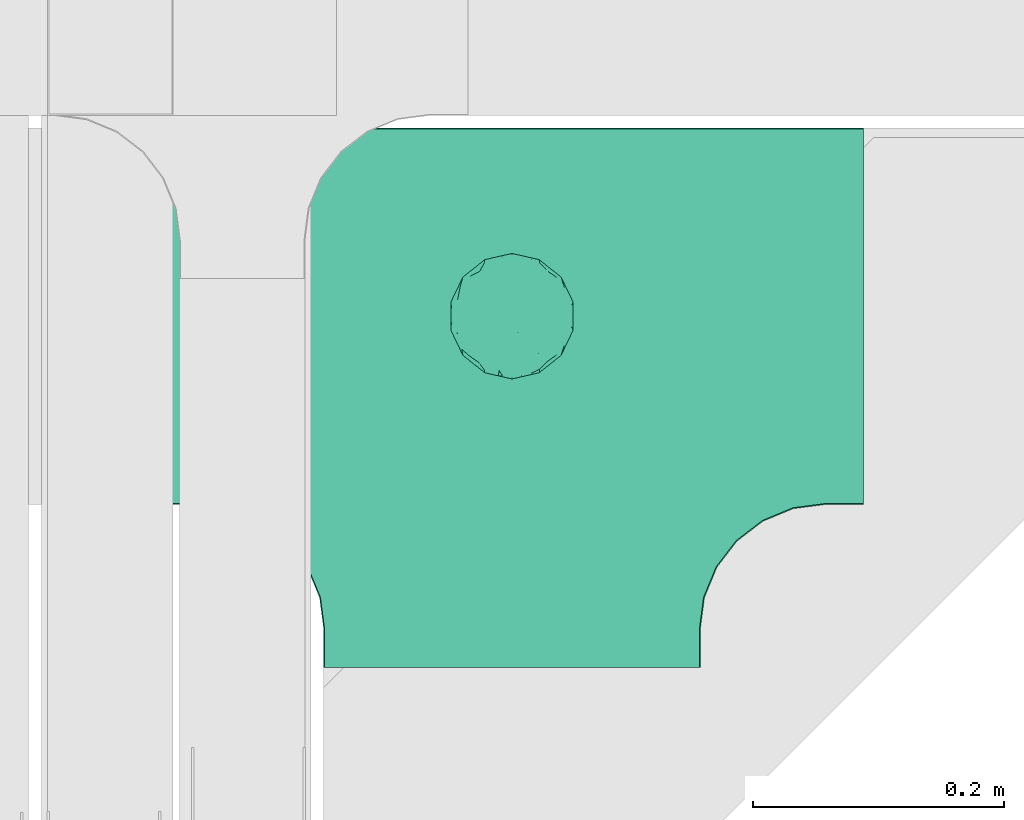
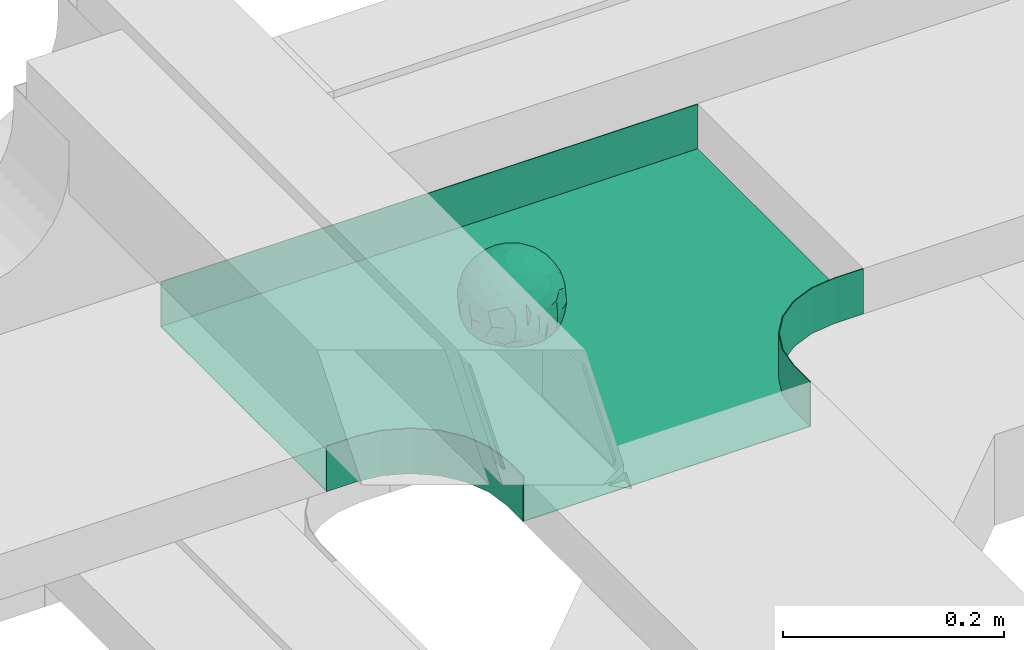
# One storey, part 29 of 33: 1 flow fitting.
"""IFC2X3 building model written with IfcOpenShell, lengths in millimetres."""

from ifc_helpers import new_model, entity, si_unit, converted_unit, derived_unit, direction, frame, origin, place, context, subcontext, project, spatial, faceted_brep, source, transform, mapped, material, material_list, type_object, type_shapes, element, save


model = new_model("IFC2X3")

# Units and contexts
model_context = context("Model", 3, precision=0.01, world=origin(), true_north=direction((6.12303176911189e-17, 1.0)))
body_context = subcontext(model_context, "Body", "Model", "MODEL_VIEW")
ifc_project = project(units=[si_unit("LENGTHUNIT", "METRE", prefix="MILLI"), si_unit("AREAUNIT", "SQUARE_METRE"), si_unit("VOLUMEUNIT", "CUBIC_METRE"), converted_unit("PLANEANGLEUNIT", "DEGREE", entity("IfcRatioMeasure", 0.0174532925199433), si_unit("PLANEANGLEUNIT", "RADIAN"), dimensions=[0, 0, 0, 0, 0, 0, 0]), si_unit("MASSUNIT", "GRAM", prefix="KILO"), derived_unit("MASSDENSITYUNIT", [(si_unit("MASSUNIT", "GRAM", prefix="KILO"), 1), (si_unit("LENGTHUNIT", "METRE"), -3)]), derived_unit("MOMENTOFINERTIAUNIT", [(si_unit("LENGTHUNIT", "METRE"), 4)]), si_unit("TIMEUNIT", "SECOND"), si_unit("FREQUENCYUNIT", "HERTZ"), si_unit("THERMODYNAMICTEMPERATUREUNIT", "DEGREE_CELSIUS"), derived_unit("THERMALTRANSMITTANCEUNIT", [(si_unit("MASSUNIT", "GRAM", prefix="KILO"), 1), (si_unit("THERMODYNAMICTEMPERATUREUNIT", "KELVIN"), -1), (si_unit("TIMEUNIT", "SECOND"), -3)]), derived_unit("VOLUMETRICFLOWRATEUNIT", [(si_unit("LENGTHUNIT", "METRE"), 3), (si_unit("TIMEUNIT", "SECOND"), -1)]), derived_unit("MASSFLOWRATEUNIT", [(si_unit("MASSUNIT", "GRAM", prefix="KILO"), 1), (si_unit("TIMEUNIT", "SECOND"), -1)]), derived_unit("ROTATIONALFREQUENCYUNIT", [(si_unit("TIMEUNIT", "SECOND"), -1)]), si_unit("ELECTRICCURRENTUNIT", "AMPERE"), si_unit("ELECTRICVOLTAGEUNIT", "VOLT"), si_unit("POWERUNIT", "WATT"), si_unit("FORCEUNIT", "NEWTON", prefix="KILO"), si_unit("ILLUMINANCEUNIT", "LUX"), si_unit("LUMINOUSFLUXUNIT", "LUMEN"), si_unit("LUMINOUSINTENSITYUNIT", "CANDELA"), derived_unit("USERDEFINED", [(si_unit("MASSUNIT", "GRAM", prefix="KILO"), -1), (si_unit("LENGTHUNIT", "METRE"), -2), (si_unit("TIMEUNIT", "SECOND"), 3), (si_unit("LUMINOUSFLUXUNIT", "LUMEN"), 1)]), derived_unit("LINEARVELOCITYUNIT", [(si_unit("LENGTHUNIT", "METRE"), 1), (si_unit("TIMEUNIT", "SECOND"), -1)]), si_unit("PRESSUREUNIT", "PASCAL"), derived_unit("USERDEFINED", [(si_unit("LENGTHUNIT", "METRE"), -2), (si_unit("MASSUNIT", "GRAM", prefix="KILO"), 1), (si_unit("TIMEUNIT", "SECOND"), -2)]), derived_unit("LINEARFORCEUNIT", [(si_unit("MASSUNIT", "GRAM", prefix="KILO"), 1), (si_unit("LENGTHUNIT", "METRE"), 1), (si_unit("TIMEUNIT", "SECOND"), -2), (si_unit("LENGTHUNIT", "METRE"), -1)]), derived_unit("PLANARFORCEUNIT", [(si_unit("MASSUNIT", "GRAM", prefix="KILO"), 1), (si_unit("LENGTHUNIT", "METRE"), 1), (si_unit("TIMEUNIT", "SECOND"), -2), (si_unit("LENGTHUNIT", "METRE"), -2)])], contexts=[model_context])

# Site, building, storey
site_placement = place(None, frame((0.0, -0.00077364408347762, 0.0)))
site = spatial("IfcSite", under=ifc_project, at=site_placement, CompositionType="ELEMENT")
building_placement = place(site_placement, origin())
building = spatial("IfcBuilding", under=site, at=building_placement, CompositionType="ELEMENT")
storey_placement = place(building_placement, frame((0.0, 0.0, 8100.0)))
storey = spatial("IfcBuildingStorey", under=building, at=storey_placement, CompositionType="ELEMENT", Elevation=8100.0)

# Flow fitting
ifc_material_1 = material()
ifc_material_2 = material()
ifc_material_list = material_list([ifc_material_1, ifc_material_2])
cable_carrier_fitting_type = type_object("IfcCableCarrierFittingType", PredefinedType="NOTDEFINED", material=ifc_material_1)
shared_shape = source(origin(), body_context, "Body", "Brep", [
    faceted_brep([(43.65414201495, -13.6159823941412, -20.221792907194), (44.7734537304832, 0.0, -22.2561865791168), (48.2627667869764, -5.5982238187369, -11.8053052540677), (16.6591030416451, 5.32882774998004, -46.8409850521773), (11.5556000970565, -8.32997143460759, -47.9278591457525), (2.01883462715812, 2.6979389970297, -49.8863250993269), (-7.81264210311725, -35.946586740035, -33.8645171988286), (-17.2052206683237, -38.2719861359275, -27.1888848422606), (-11.1277274207927, -27.3202044092451, -40.3705352142543), (37.7030088371667, -7.24923843471304, -32.0301680723234), (10.6384317789277, 26.5155476513889, -41.0335168128579), (19.2127839264957, 19.8412508508062, -41.6796556903778), (10.4192511908907, 17.8098221318595, -45.5439286870577), (48.7463956090969, 0.0, 0.0), (48.0667721403428, 6.51594663441988, -12.1296271775358), (-37.4554170352858, 12.1627069007925, -30.8084451986326), (-31.3452178059555, 12.1462454498318, -37.0127821457472), (-38.0909108580228, 3.52194087904066, -32.1974912446565), (48.7463956090969, 11.1260466978072, 0.0), (9.66670567763161, 42.5651334019307, -24.3877883338551), (17.4761229293595, 37.974251726212, -27.4324868211278), (8.3452685270067, 35.3634447252368, -34.3479733081336), (36.7018152786982, 20.4309971840494, -27.121045505536), (28.2201055605836, 12.5803931374896, -39.3110588849404), (28.3969378462537, 24.0066360557188, -33.4259681422047), (37.1036906899333, 7.75177236926259, -32.6071489449891), (30.3928805396455, 38.1114667440203, 0.0), (34.7422273315263, 34.6429784184742, 0.0), (32.9402906787036, 32.1278050479557, -19.5637775698511), (26.0435337477646, 41.5799550695664, 0.0), (-44.7734518080776, 0.0, -22.2561904464559), (-35.9183276906112, -8.71634506105637, -33.6734177755349), (-42.698067512074, -12.1858404892465, -22.9865247983333), (5.42354673897514, -48.7621108487887, 0.0), (2.92058716488888e-07, -48.7843224693665, -10.9585528791684), (7.58713024513234, -47.4313421101439, -13.8817592643935), (33.995370401777, -31.6485911362954, -18.5116576873667), (40.0066375577234, -26.2448741379086, -14.5146661281262), (30.3928805396453, -38.1114667440373, 0.0), (-47.5540080368347, -8.6499737676748, -12.798213682019), (43.918984866252, -21.1502683953847, 0.0), (-47.5463631702337, 8.67950108284767, -12.8066236860544), (-43.9189848662407, 21.1502683953677, 0.0), (-41.5587306666804, 23.544384411141, -14.7828910593852), (-36.7018137075475, 20.43099797302, -27.1210470373429), (-42.6812093094125, 12.162707383776, -23.0300438771125), (-0.0435489182880873, -44.6798423199703, -22.4434799831651), (43.3459115209922, 13.125713179152, -21.1860238825719), (-9.67158541810518, -42.815796006327, -23.9430166822217), (2.9348104480415, -38.3026865671621, -32.0045479482528), (10.5768620896568, -32.3565839798164, -36.6221444141874), (17.476122931187, -37.9742517249799, -27.4324868216925), (29.4150529887209, -14.2918330913411, -37.8219270339311), (29.2594402117981, 0.0, -40.5448536622337), (-34.742227331515, 34.6429784184742, 0.0), (-35.5934709721032, 30.8679809236437, -16.7413433706631), (16.2706402169142, 46.2863325463322, 0.0), (15.3978227309257, 45.3692296018892, -14.301750259225), (10.8470934779447, 47.524221697552, 0.0), (-22.0930685137321, 42.2576087042555, -15.0396419586498), (-16.2706402169028, 46.2863325463322, 0.0), (-15.3976096147999, 45.3685960862683, -14.3039892096614), (-35.5741674477324, -30.877857614309, -16.7641438657341), (-34.7422273315149, -34.6429784184913, 0.0), (-41.544749127214, -23.5699215759022, -14.7814957586296), (-21.2012609977656, -29.9118129495041, -33.9969113035032), (-22.0930685137892, -42.2576087036302, -15.0396419603704), (-28.5890959469058, -35.7745555449591, -20.0709932115786), (27.967317375364, -26.9235432392394, -31.5111405422078), (26.5630985649032, -36.7540375314827, -21.0604491824418), (-4.69743067705244, -12.8233951627736, -48.0988012484001), (-3.71385705669819, -22.0483048804436, -44.7222485756373), (7.046128924104e-07, -29.8515321197025, -40.1109215813634), (-8.78090686085946, 23.4705297392872, -43.266960933916), (-10.7087237416586, 12.1533783795858, -47.3034737602475), (-19.1851128431225, 19.8122800241045, -41.7061746680507), (19.2127839279743, -19.841250849511, -41.6796556903208), (10.2736167511021, -43.2535488218696, -22.8819429499797), (-16.2706402169027, -46.2863325463492, 0.0), (-15.4179487650123, -45.4307793041134, -14.0830091848577), (-10.8470934779332, -47.524221697569, 0.0), (-21.6941869558721, -45.0484433951294, 0.0), (-26.043533747753, -41.5799550695834, 0.0), (-30.3928805396339, -38.1114667440373, 0.0), (-26.9077773704145, -11.7097120961444, -40.4827637348157), (-28.5735237959864, -22.531789977659, -34.2909926698312), (-14.3485559949731, 0.554718003800719, -47.8937493708156), (20.3912706461748, 29.6966950280778, -34.6742323035854), (25.8798715159051, 35.5620355309087, -23.7817972243053), (-1.90439589452332, 38.2956374757213, -32.090768557389), (-0.0435489197807358, 44.6798423204566, -22.4434799821603), (-9.54280395759116, 42.6678856642021, -24.2566779582937), (-10.1209262269152, 33.0365306692783, -36.140759450321), (-17.2052206685055, 38.2719861378047, -27.1888848394794), (-28.5890959468196, 35.7745555453602, -20.0709932109564), (-30.3928805396341, 38.1114667440203, 0.0), (-26.0435337477532, 41.5799550695664, 0.0), (-21.6941869558723, 45.0484433951125, 0.0), (0.920553890736952, 16.9936143333855, -47.0145685125519), (7.01705705346737e-07, 29.8515321215381, -40.1109215799846), (-28.4299335912282, 23.6392950735915, -33.6589156750601), (22.0754283900311, -42.7194435884069, -13.7012627481666), (0.0, -50.0, 0.0), (-7.98433520770671, 47.2879675743241, -14.1456181900809), (-10.8470934779333, 47.524221697552, 0.0), (-5.42354673896381, 48.7621108487718, 0.0), (-39.0915741233958, -31.1744900929452, 0.0), (-36.7018137083218, -20.4309979729983, -27.1210470363242), (-20.0503020227076, 29.8835350153312, -34.7125297808217), (48.7463956090969, -11.1260466978243, 0.0), (36.7018152787698, -20.430997183803, -27.1210455056374), (39.0915741234071, -31.1744900929452, 0.0), (43.9189848662521, 21.1502683953677, 0.0), (41.0372234357161, 24.481336168204, -14.7176924857918), (21.4315363761966, -9.86715979165204, -44.0831986838696), (19.8461085062156, -30.3026908878047, -34.4656191315041), (26.0435337477644, -41.5799550695834, 0.0), (8.27678352490751, -22.6176025005053, -43.8171075221857), (-19.1851128386707, -19.8122800229913, -41.7061746706354), (-17.559283921422, -9.66340012518247, -45.8070982074481), (-29.2594384269524, -1.64502744759432e-09, -40.5448549502702), (-22.2759109836818, 8.45458562997746, -43.957977338265), (21.6941869558835, -45.0484433951294, 0.0), (-7.7537430917927, -47.3248906716555, -14.1504131029038), (22.0929359888287, 42.3611643932195, -14.7456410726513), (21.6941869558837, 45.0484433951125, 0.0), (7.94480963874029, 47.2524194975214, -14.285966940796), (5.42354673897518, 48.7621108487718, 0.0), (-43.9189848662406, -21.1502683953848, 0.0), (-39.0915741233959, 31.1744900929281, 0.0), (-48.7463956090855, 11.1260466978072, 0.0), (-48.7463956090855, -11.1260466978243, 0.0), (-48.7463956090855, 0.0, 0.0), (0.0, 50.0, 0.0), (2.95674852821199e-07, 48.76542105366, -11.0423597776141), (-5.42354673896377, -48.7621108487887, 0.0), (16.2706402169141, -46.2863325463492, 0.0), (10.8470934779446, -47.524221697569, 0.0), (39.0915741234072, 31.1744900929281, 0.0), (34.7422273315262, -34.6429784184913, 0.0), (-43.6541417785539, -13.6159824952714, 20.2217933494142), (-44.7734534735007, 0.0, 22.2561870960884), (-48.2627667188257, -5.59822380837423, 11.8053055375658), (-16.6591016552529, 5.32882757852047, 46.8409855647676), (-11.5555985538933, -8.32997141356845, 47.9278595214841), (-2.01883285210585, 2.69793886619285, 49.8863251782511), (7.81264298940045, -35.9465866899564, 33.8645170475355), (17.2052219498432, -38.2719853643866, 27.1888851173795), (11.1277291939633, -27.3202042660781, 40.370534822402), (-37.7030082707847, -7.24923849358482, 32.0301687256941), (-10.6384306361632, 26.5155474098453, 41.0335172652288), (-19.2127828542464, 19.8412506695278, 41.6796562709507), (-10.419249902145, 17.8098220464058, 45.5439290153173), (-48.0667720467311, 6.51594672713361, 12.1296274986609), (37.4554198551597, 12.1627053911885, 30.8084423663635), (31.3452204336626, 12.1462444514283, 37.0127802480704), (38.0909129847824, 3.52193921618223, 32.1974889105362), (-9.66670492251031, 42.565133342123, 24.3877887375616), (-17.4761222809685, 37.9742516795029, 27.4324872988574), (-8.34526747232003, 35.3634445391436, 34.3479737559899), (-36.7018147879525, 20.4309972885889, 27.1210460908894), (-28.2201045883605, 12.5803929822385, 39.3110596325575), (-28.3969371324566, 24.0066357536882, 33.4259689655335), (-37.1036900366786, 7.75177247673037, 32.6071496627812), (-32.9402901163369, 32.1278052689131, 19.5637781538672), (44.773453728735, 0.0, 22.2561865826485), (35.9183286182219, -8.71634518545332, 33.6734167539099), (42.6980684782056, -12.1858381773451, 22.9865242293622), (-5.1564557811304e-08, -48.7843224155168, 10.9585531189064), (-7.58712982046247, -47.4313421866568, 13.8817592350767), (-33.9953700157816, -31.6485912778883, 18.5116581541388), (-40.0066373233245, -26.2448743223541, 14.5146664406737), (47.5540088657557, -8.64997340643016, 12.7982108462298), (47.5463641063755, 8.67950029611492, 12.8066207437518), (41.5587323717035, 23.5443822102692, 14.7828897714275), (36.7018153946169, 20.4309968399072, 27.121045607934), (42.6812105193328, 12.1627054070682, 23.0300426787683), (0.0435498934198039, -44.6798421141237, 22.4434803910813), (-43.3459112327239, 13.1257132261269, 21.1860244432478), (9.6715868653752, -42.8157959611257, 23.9430161784588), (-2.93481023367521, -38.3026862522726, 32.0045483447802), (-10.5768615382775, -32.3565831315815, 36.6221453228799), (-17.4761222811971, -37.9742516793303, 27.4324872989742), (-29.4150522011614, -14.2918331221065, 37.8219276348162), (-29.259439267976, 0.0, 40.5448543433553), (35.593472529025, 30.867979902287, 16.7413419437535), (-15.3978225621776, 45.3692295068837, 14.3017507422931), (22.0930688164668, 42.2576085856364, 15.0396418472572), (15.3976099169387, 45.3685960801975, 14.3039889037045), (35.5741692798952, -30.8778564526781, 16.7641421174582), (41.5447510295928, -23.5699190140567, 14.7814944968718), (21.2012629219892, -29.9118119699372, 33.9969109653959), (22.0930688164889, -42.2576085855628, 15.039641847479), (28.5890966709526, -35.7745557157875, 20.0709918757936), (-27.9673166448933, -26.9235432178776, 31.5111412087844), (-26.5630981091642, -36.7540374223405, 21.0604499477277), (4.69743244094294, -12.8233948182002, 48.0988011680158), (3.71385918047916, -22.0483045188225, 44.7222485775695), (6.0892732202368e-07, -29.8515316280668, 40.1109219472655), (8.78090833347225, 23.4705290601204, 43.2669610034903), (10.7087255323208, 12.1533779204354, 47.3034734728551), (19.1851144535653, 19.8122792782791, 41.7061742815566), (-19.212782854423, -19.8412506693283, 41.6796562709723), (-10.2736163541564, -43.2535491498667, 22.8819425082012), (15.4179491053271, -45.430779442795, 14.0830083649343), (26.9077783310918, -11.7097109554472, 40.4827634262511), (28.5735255699879, -22.531788297607, 34.2909922955619), (14.3485579041194, 0.554717908736034, 47.893748799971), (-20.3912698186306, 29.6966949125693, 34.674232889184), (-25.8798708903081, 35.5620354347035, 23.7817980489561), (1.90439718168615, 38.2956370656312, 32.0907689704016), (0.0435498935700709, 44.6798421141929, 22.4434803909095), (9.54280511870019, 42.6678852802435, 24.2566781769111), (10.1209277017953, 33.036529901429, 36.1407597392074), (17.2052219497738, 38.2719853646937, 27.1888851169673), (28.5890966709116, 35.7745557157488, 20.0709918758907), (-0.920552500958269, 16.993613961591, 47.0145686741652), (6.09264554473049e-07, 29.8515316283504, 40.1109219470418), (28.4299352793349, 23.6392936643312, 33.6589152389788), (-22.0754282965694, -42.7194435788052, 13.7012629286858), (7.9843354212563, 47.2879674404261, 14.1456185171795), (36.7018153946056, -20.4309968401043, 27.1210456078136), (20.0503035663584, 29.8835340747136, 34.7125296989797), (-36.7018147879654, -20.4309972885437, 27.1210460909186), (-41.0372232425556, 24.4813362747081, 14.7176928472045), (-21.4315352776288, -9.8671595900376, 44.0831992630873), (-19.8461080318002, -30.3026912052829, 34.4656191255603), (-8.27678185920825, -22.617601585775, 43.8171083090061), (19.1851144530605, -19.8122792780652, 41.7061742818985), (17.5592847966676, -9.6634000411993, 45.8070978896755), (29.259440221343, 0.0, 40.5448536553604), (22.2759127990671, 8.45458631346954, 43.9579762868721), (7.75374356219277, -47.3248906381916, 14.1504129570858), (-22.0929358819219, 42.3611643749655, 14.7456412852645), (-7.94480944914509, 47.2524194744515, 14.2859671225497), (-5.23333520595152e-08, 48.7654210084985, 11.0423599770715)], [[[0, 1, 2]], [[3, 4, 5]], [[6, 7, 8]], [[1, 0, 9]], [[10, 11, 12]], [[13, 2, 14]], [[15, 16, 17]], [[14, 18, 13]], [[19, 20, 21]], [[22, 23, 24]], [[1, 9, 25]], [[26, 27, 28, 29]], [[30, 31, 32]], [[33, 34, 35]], [[36, 37, 38]], [[32, 39, 30]], [[2, 40, 0]], [[23, 22, 25]], [[41, 42, 43]], [[44, 15, 45]], [[46, 35, 34]], [[25, 22, 47]], [[31, 30, 17]], [[48, 49, 46]], [[50, 51, 49]], [[52, 53, 9]], [[43, 54, 55]], [[56, 57, 58]], [[59, 60, 61]], [[62, 63, 64]], [[8, 7, 65]], [[7, 66, 67]], [[68, 36, 69]], [[70, 5, 4]], [[8, 71, 72]], [[73, 74, 75]], [[68, 76, 52]], [[77, 46, 49]], [[78, 79, 80]], [[7, 6, 48]], [[67, 81, 82, 83]], [[84, 85, 31]], [[85, 65, 67]], [[70, 86, 5]], [[23, 3, 11]], [[21, 87, 10]], [[21, 20, 87]], [[28, 24, 88]], [[19, 89, 90]], [[91, 90, 89]], [[91, 92, 93]], [[94, 95, 96, 97]], [[98, 99, 10]], [[100, 16, 44]], [[77, 51, 101]], [[33, 102, 34]], [[103, 91, 61]], [[93, 59, 61]], [[104, 105, 103]], [[106, 64, 63]], [[107, 31, 85]], [[100, 94, 108]], [[108, 93, 92]], [[43, 55, 44]], [[0, 40, 37]], [[2, 13, 109]], [[2, 1, 14]], [[110, 9, 0]], [[2, 109, 40]], [[37, 40, 111]], [[47, 14, 1]], [[112, 14, 47]], [[113, 112, 47]], [[112, 18, 14]], [[47, 22, 113]], [[52, 9, 110]], [[53, 25, 9]], [[25, 47, 1]], [[23, 25, 53]], [[68, 52, 110]], [[76, 4, 114]], [[51, 115, 69]], [[50, 115, 51]], [[110, 36, 68]], [[3, 23, 53]], [[23, 11, 24]], [[52, 76, 114]], [[98, 12, 5]], [[11, 87, 24]], [[24, 28, 22]], [[87, 88, 24]], [[36, 116, 69]], [[28, 27, 113]], [[114, 3, 53]], [[76, 115, 117]], [[70, 4, 117]], [[118, 84, 119]], [[119, 70, 118]], [[120, 16, 121]], [[37, 36, 110]], [[116, 36, 38]], [[116, 122, 69]], [[34, 123, 46]], [[10, 87, 11]], [[87, 20, 88]], [[12, 98, 10]], [[10, 99, 21]], [[74, 5, 86]], [[73, 75, 108]], [[124, 56, 125]], [[124, 29, 88]], [[89, 21, 99]], [[21, 89, 19]], [[92, 89, 99]], [[89, 92, 91]], [[126, 127, 58]], [[88, 29, 28]], [[20, 57, 124]], [[88, 20, 124]], [[57, 20, 19]], [[73, 92, 99]], [[92, 73, 108]], [[99, 98, 73]], [[74, 86, 121]], [[73, 98, 74]], [[5, 74, 98]], [[100, 108, 75]], [[94, 93, 108]], [[86, 120, 121]], [[100, 44, 55]], [[75, 16, 100]], [[17, 16, 120]], [[31, 17, 120]], [[17, 30, 45]], [[84, 31, 120]], [[31, 107, 32]], [[41, 45, 30]], [[43, 44, 45]], [[107, 64, 32]], [[39, 64, 128]], [[30, 39, 41]], [[129, 43, 42]], [[41, 130, 42]], [[43, 45, 41]], [[62, 83, 63]], [[95, 94, 55]], [[100, 55, 94]], [[64, 107, 62]], [[131, 39, 128]], [[64, 106, 128]], [[85, 62, 107]], [[67, 83, 62]], [[39, 32, 64]], [[130, 41, 132]], [[59, 97, 60]], [[133, 127, 134]], [[59, 94, 97]], [[104, 61, 60]], [[94, 59, 93]], [[126, 134, 127]], [[126, 58, 57]], [[19, 90, 126]], [[134, 105, 133]], [[126, 90, 134]], [[103, 90, 91]], [[105, 134, 103]], [[90, 103, 134]], [[119, 120, 86]], [[84, 118, 85]], [[65, 85, 118]], [[62, 85, 67]], [[8, 65, 118]], [[67, 65, 7]], [[71, 118, 70]], [[8, 72, 6]], [[49, 6, 72]], [[6, 49, 48]], [[50, 49, 72]], [[77, 49, 51]], [[101, 69, 122]], [[123, 34, 135]], [[101, 122, 136]], [[137, 77, 136]], [[78, 81, 66]], [[7, 79, 66]], [[67, 66, 81]], [[79, 7, 48]], [[35, 137, 33]], [[123, 80, 79]], [[135, 34, 102]], [[35, 46, 77]], [[80, 123, 135]], [[46, 123, 48]], [[117, 50, 72]], [[115, 76, 68]], [[117, 72, 71]], [[4, 76, 117]], [[39, 132, 41]], [[39, 131, 132]], [[137, 35, 77]], [[124, 57, 56]], [[126, 57, 19]], [[103, 61, 104]], [[61, 91, 93]], [[77, 101, 136]], [[51, 69, 101]], [[28, 113, 22]], [[112, 113, 138]], [[16, 75, 121]], [[74, 121, 75]], [[66, 79, 78]], [[123, 79, 48]], [[0, 37, 110]], [[37, 111, 139, 38]], [[29, 124, 125]], [[115, 50, 117]], [[69, 115, 68]], [[120, 119, 84]], [[70, 119, 86]], [[11, 3, 12]], [[5, 12, 3]], [[118, 71, 8]], [[117, 71, 70]], [[3, 114, 4]], [[53, 52, 114]], [[27, 138, 113]], [[45, 15, 17]], [[44, 16, 15]], [[55, 54, 95]], [[43, 129, 54]], [[140, 141, 142]], [[143, 144, 145]], [[146, 147, 148]], [[141, 140, 149]], [[150, 151, 152]], [[132, 142, 153]], [[154, 155, 156]], [[153, 130, 132]], [[157, 158, 159]], [[160, 161, 162]], [[141, 149, 163]], [[95, 54, 164, 96]], [[165, 166, 167]], [[135, 168, 169]], [[170, 171, 83]], [[167, 172, 165]], [[142, 141, 153]], [[161, 160, 163]], [[173, 112, 174]], [[175, 154, 176]], [[177, 169, 168]], [[163, 160, 178]], [[166, 165, 156]], [[179, 180, 177]], [[181, 182, 180]], [[183, 184, 149]], [[174, 27, 185]], [[60, 186, 104]], [[187, 56, 188]], [[189, 139, 190]], [[148, 147, 191]], [[147, 192, 193]], [[194, 170, 195]], [[196, 145, 144]], [[148, 197, 198]], [[199, 200, 201]], [[194, 202, 183]], [[203, 177, 180]], [[136, 204, 137]], [[147, 146, 179]], [[193, 122, 116, 38]], [[205, 206, 166]], [[206, 191, 193]], [[196, 207, 145]], [[161, 143, 151]], [[159, 208, 150]], [[159, 158, 208]], [[164, 162, 209]], [[157, 210, 211]], [[212, 211, 210]], [[212, 213, 214]], [[215, 26, 29, 125]], [[216, 217, 150]], [[218, 155, 175]], [[203, 182, 219]], [[135, 102, 168]], [[220, 212, 188]], [[214, 187, 188]], [[58, 127, 220]], [[111, 190, 139]], [[221, 166, 206]], [[218, 215, 222]], [[222, 214, 213]], [[174, 185, 175]], [[171, 140, 128]], [[132, 131, 142]], [[142, 128, 140]], [[223, 149, 140]], [[142, 131, 128]], [[171, 128, 106]], [[178, 153, 141]], [[42, 153, 178]], [[224, 42, 178]], [[42, 130, 153]], [[178, 160, 224]], [[183, 149, 223]], [[184, 163, 149]], [[163, 178, 141]], [[161, 163, 184]], [[194, 183, 223]], [[202, 144, 225]], [[182, 226, 195]], [[181, 226, 182]], [[223, 170, 194]], [[143, 161, 184]], [[161, 151, 162]], [[183, 202, 225]], [[216, 152, 145]], [[151, 208, 162]], [[162, 164, 160]], [[208, 209, 162]], [[170, 82, 195]], [[164, 54, 224]], [[225, 143, 184]], [[202, 226, 227]], [[196, 144, 227]], [[228, 205, 229]], [[229, 196, 228]], [[230, 155, 231]], [[171, 170, 223]], [[82, 170, 83]], [[82, 81, 195]], [[168, 232, 177]], [[150, 208, 151]], [[208, 158, 209]], [[152, 216, 150]], [[150, 217, 159]], [[200, 145, 207]], [[199, 201, 222]], [[233, 60, 97]], [[233, 96, 209]], [[210, 159, 217]], [[159, 210, 157]], [[213, 210, 217]], [[210, 213, 212]], [[234, 105, 104]], [[209, 96, 164]], [[158, 186, 233]], [[209, 158, 233]], [[186, 158, 157]], [[199, 213, 217]], [[213, 199, 222]], [[217, 216, 199]], [[200, 207, 231]], [[199, 216, 200]], [[145, 200, 216]], [[218, 222, 201]], [[215, 214, 222]], [[207, 230, 231]], [[218, 175, 185]], [[201, 155, 218]], [[156, 155, 230]], [[166, 156, 230]], [[156, 165, 176]], [[205, 166, 230]], [[166, 221, 167]], [[173, 176, 165]], [[174, 175, 176]], [[221, 190, 167]], [[172, 190, 40]], [[165, 172, 173]], [[138, 174, 112]], [[173, 18, 112]], [[174, 176, 173]], [[189, 38, 139]], [[26, 215, 185]], [[218, 185, 215]], [[190, 221, 189]], [[109, 172, 40]], [[190, 111, 40]], [[206, 189, 221]], [[193, 38, 189]], [[172, 167, 190]], [[18, 173, 13]], [[187, 125, 56]], [[133, 105, 235]], [[187, 215, 125]], [[58, 188, 56]], [[215, 187, 214]], [[234, 235, 105]], [[234, 104, 186]], [[157, 211, 234]], [[235, 127, 133]], [[234, 211, 235]], [[220, 211, 212]], [[127, 235, 220]], [[211, 220, 235]], [[229, 230, 207]], [[205, 228, 206]], [[191, 206, 228]], [[189, 206, 193]], [[148, 191, 228]], [[193, 191, 147]], [[197, 228, 196]], [[148, 198, 146]], [[180, 146, 198]], [[146, 180, 179]], [[181, 180, 198]], [[203, 180, 182]], [[219, 195, 81]], [[232, 168, 33]], [[219, 81, 78]], [[80, 203, 78]], [[136, 122, 192]], [[147, 204, 192]], [[193, 192, 122]], [[204, 147, 179]], [[169, 80, 135]], [[232, 137, 204]], [[33, 168, 102]], [[169, 177, 203]], [[137, 232, 33]], [[177, 232, 179]], [[227, 181, 198]], [[226, 202, 194]], [[227, 198, 197]], [[144, 202, 227]], [[172, 13, 173]], [[172, 109, 13]], [[80, 169, 203]], [[233, 186, 60]], [[234, 186, 157]], [[220, 188, 58]], [[188, 212, 214]], [[203, 219, 78]], [[182, 195, 219]], [[164, 224, 160]], [[42, 224, 129]], [[155, 201, 231]], [[200, 231, 201]], [[192, 204, 136]], [[232, 204, 179]], [[140, 171, 223]], [[171, 106, 63, 83]], [[96, 233, 97]], [[226, 181, 227]], [[195, 226, 194]], [[230, 229, 205]], [[196, 229, 207]], [[151, 143, 152]], [[145, 152, 143]], [[228, 197, 148]], [[227, 197, 196]], [[143, 225, 144]], [[184, 183, 225]], [[54, 129, 224]], [[176, 154, 156]], [[175, 155, 154]], [[185, 27, 26]], [[174, 138, 27]]]),
    faceted_brep([(-153.407417371086, -224.118095489753, 25.0), (-150.0, -250.0, 25.0), (-150.0, -280.0, 25.0), (-149.199999999993, -280.0, 25.0), (-149.199999999993, -250.0, 25.0), (-152.634676710055, -223.911040253671, 25.0), (-162.704639298522, -199.600000000004, 25.0), (-178.723636456391, -178.7236364564, 25.0), (-199.599999999996, -162.704639298532, 25.0), (-223.911040253663, -152.634676710066, 25.0), (-250.0, -149.200000000004, 25.0), (-280.0, -149.200000000004, 25.0), (-280.0, -150.0, 25.0), (-250.0, -150.0, 25.0), (-224.118095489745, -153.407417371099, 25.0), (-200.0, -163.397459621561, 25.0), (-179.28932188134, -179.289321881349, 25.0), (-163.39745962155, -200.0, 25.0), (280.0, -150.0, 25.0), (280.0, -149.200000000004, 25.0), (250.0, -149.200000000007, 25.0), (223.911040253719, -152.634676710068, 25.0), (199.600000000048, -162.704639298534, 25.0), (178.723636456437, -178.7236364564, 25.0), (162.70463929856, -199.600000000004, 25.0), (152.634676710083, -223.91104025367, 25.0), (149.200000000009, -250.0, 25.0), (149.200000000007, -280.0, 25.0), (150.0, -280.0, 25.0), (150.0, -250.0, 25.0), (153.407417371116, -224.118095489752, 25.0), (163.39745962159, -200.0, 25.0), (179.289321881388, -179.289321881351, 25.0), (200.0, -163.397459621564, 25.0), (224.118095489802, -153.407417371102, 25.0), (250.0, -150.0, 25.0), (280.0, 149.199999999995, 25.0), (280.0, 150.0, 25.0), (-280.0, 150.0, 25.0), (-280.0, 149.199999999995, 25.0), (-280.0, -150.0, -25.0), (-280.0, 150.0, -25.0), (280.0, 150.0, -25.0), (280.0, -150.0, -25.0), (250.0, -150.0, -25.0), (224.118095489802, -153.407417371102, -25.0), (200.0, -163.397459621564, -25.0), (179.289321881388, -179.289321881351, -25.0), (163.39745962159, -200.0, -25.0), (153.407417371116, -224.118095489752, -25.0), (150.0, -250.0, -25.0), (150.0, -280.0, -25.0), (-150.0, -280.0, -25.0), (-150.0, -250.0, -25.0), (-153.407417371086, -224.118095489753, -25.0), (-163.39745962155, -200.0, -25.0), (-179.28932188134, -179.289321881349, -25.0), (-200.0, -163.397459621561, -25.0), (-224.118095489745, -153.407417371099, -25.0), (-250.0, -150.0, -25.0), (-150.0, -250.0, -24.199999999986), (149.200000000007, -280.0, -24.199999999986), (-149.199999999993, -280.0, -24.199999999986), (-149.199999999993, -250.0, -24.199999999986), (-250.0, -149.200000000004, -24.199999999986), (-280.0, -149.200000000004, -24.199999999986), (280.0, -149.200000000004, -24.199999999986), (250.0, -149.200000000004, -24.199999999986), (-280.0, 149.199999999995, -24.199999999986), (-250.0, -150.0, -24.199999999986), (250.0, -150.0, -24.199999999986), (280.0, 149.199999999995, -24.199999999986), (149.200000000009, -250.0, -24.199999999986), (150.0, -250.0, -24.199999999986), (-223.911040253663, -152.634676710066, -24.199999999986), (-199.599999999996, -162.704639298532, -24.199999999986), (-178.723636456391, -178.7236364564, -24.199999999986), (-162.704639298522, -199.600000000004, -24.199999999986), (-152.634676710055, -223.911040253671, -24.199999999986), (152.634676710083, -223.911040253671, -24.199999999986), (162.70463929856, -199.600000000004, -24.199999999986), (178.723636456436, -178.723636456401, -24.199999999986), (199.600000000047, -162.704639298534, -24.199999999986), (223.911040253719, -152.634676710069, -24.199999999986)], [[[0, 1, 2, 3, 4, 5, 6, 7, 8, 9, 10, 11, 12, 13, 14, 15, 16, 17]], [[18, 19, 20, 21, 22, 23, 24, 25, 26, 27, 28, 29, 30, 31, 32, 33, 34, 35]], [[36, 37, 38, 39]], [[40, 41, 42, 43, 44, 45, 46, 47, 48, 49, 50, 51, 52, 53, 54, 55, 56, 57, 58, 59]], [[2, 1, 60, 53, 52]], [[3, 2, 52, 51, 28, 27, 61, 62]], [[4, 3, 62, 63]], [[11, 10, 64, 65]], [[20, 19, 66, 67]], [[39, 38, 41, 40, 12, 11, 65, 68]], [[13, 12, 40, 59, 69]], [[18, 35, 70, 44, 43]], [[19, 18, 43, 42, 37, 36, 71, 66]], [[27, 26, 72, 61]], [[29, 28, 51, 50, 73]], [[38, 37, 42, 41]], [[36, 39, 68, 71]], [[68, 65, 64, 74, 75, 76, 77, 78, 63, 62, 61, 72, 79, 80, 81, 82, 83, 67, 66, 71]], [[14, 13, 69, 59, 58]], [[58, 57, 15, 14]], [[15, 57, 56, 16]], [[0, 17, 55, 54]], [[0, 54, 53, 60, 1]], [[55, 17, 16, 56]], [[5, 4, 63, 78]], [[6, 5, 78, 77]], [[7, 6, 77, 76]], [[8, 7, 76, 75]], [[9, 8, 75, 74]], [[10, 9, 74, 64]], [[21, 20, 67, 83]], [[22, 21, 83, 82]], [[23, 22, 82, 81]], [[81, 80, 24, 23]], [[24, 80, 79, 25]], [[79, 72, 26, 25]], [[30, 29, 73, 50, 49]], [[31, 30, 49, 48]], [[31, 48, 47, 32]], [[33, 32, 47, 46]], [[45, 34, 33, 46]], [[34, 45, 44, 70, 35]]]),
])
type_shapes(cable_carrier_fitting_type, [shared_shape])
flow_fitting_placement = place(storey_placement, frame((18396.0523642072, 14332.2782357464, 2865.01712441882)))
element("IfcFlowFitting", 1, at=flow_fitting_placement, inside=storey, type_object=cable_carrier_fitting_type, material=ifc_material_list, Name="470_DKC_S5_T", context=body_context, shape_type="MappedRepresentation", body=[
    mapped(shared_shape, transform((0.0, 0.0, 0.0), scale=1.0)),
])

save(model, "model.ifc")
